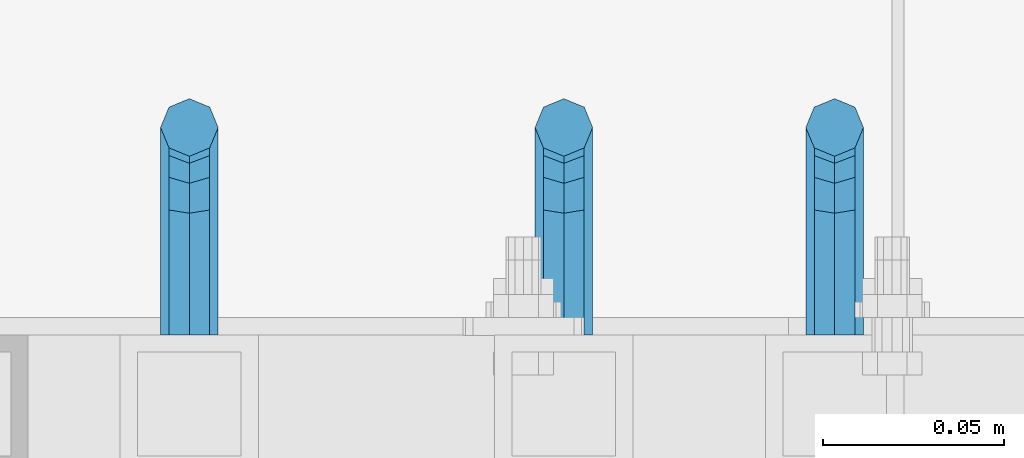
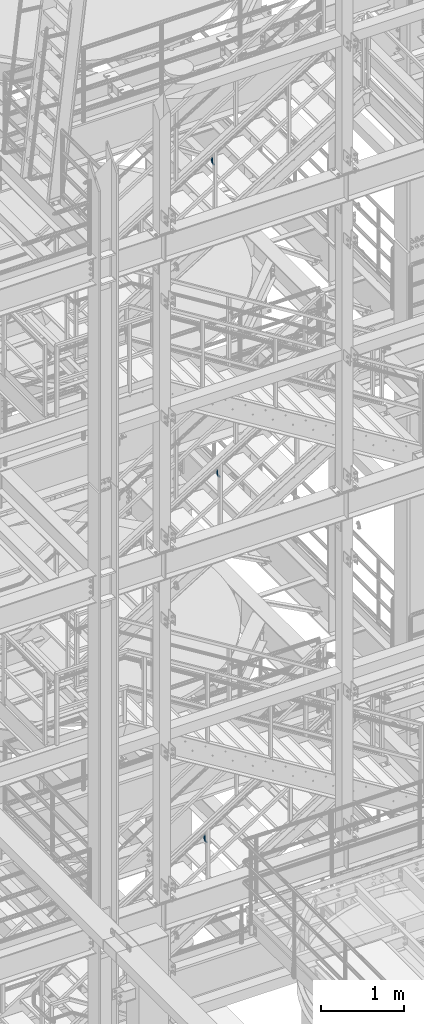
# One storey, part 1184 of 1876: 3 beams, 3 elements without a shape of their own.
"""IFC2X3 building model written with IfcOpenShell, lengths in millimetres."""

from ifc_helpers import new_model, si_unit, frame, origin_with_axes, place, context, subcontext, project, spatial, faceted_brep, material, type_object, element, aggregate, save


model = new_model("IFC2X3")

# Units and contexts
model_context = context("Model", 3, precision=1e-05, world=origin_with_axes())
body_context = subcontext(model_context, "Body", "Model", "MODEL_VIEW")
ifc_project = project(units=[si_unit("LENGTHUNIT", "METRE", prefix="MILLI"), si_unit("AREAUNIT", "SQUARE_METRE"), si_unit("VOLUMEUNIT", "CUBIC_METRE"), si_unit("MASSUNIT", "GRAM", prefix="KILO"), si_unit("TIMEUNIT", "SECOND"), si_unit("PLANEANGLEUNIT", "RADIAN"), si_unit("SOLIDANGLEUNIT", "STERADIAN"), si_unit("THERMODYNAMICTEMPERATUREUNIT", "DEGREE_CELSIUS"), si_unit("LUMINOUSINTENSITYUNIT", "LUMEN")], contexts=[model_context])

# Site, building, storey
site_placement = place(None, origin_with_axes())
site = spatial("IfcSite", under=ifc_project, at=site_placement, CompositionType="ELEMENT")
building_placement = place(site_placement, origin_with_axes())
building = spatial("IfcBuilding", under=site, at=building_placement, Name="Undefined", CompositionType="ELEMENT")
storey_placement = place(building_placement, origin_with_axes())
storey = spatial("IfcBuildingStorey", under=building, at=storey_placement, Name="Undefined", CompositionType="ELEMENT", Elevation=0.0)

# Assembly, beam
assembly_1_placement = place(storey_placement, origin_with_axes())
assembly_1 = element("IfcElementAssembly", 1, at=assembly_1_placement, inside=storey, Name="RAIL", AssemblyPlace="NOTDEFINED", PredefinedType="RIGID_FRAME")
ifc_material = material(Name="STEEL/A36")
beam_type = type_object("IfcBeamType", PredefinedType="NOTDEFINED")
beam_1_placement = place(assembly_1_placement, frame((4152.90000017992, -5715.00000114554, 12949.3240268015), z_axis=(1.0, 0.0, 0.0), x_axis=(0.0, 1.0, 0.0)))
beam_1 = element("IfcBeam", 2, at=beam_1_placement, type_object=beam_type, material=ifc_material, Name="BRACKET", context=body_context, shape_type="Brep", body=[
    faceted_brep([(0.0, -5.61266007566822, 5.61266007566883), (0.0, 0.0, 7.9375), (0.0, 5.61266007566822, 5.61266007566883), (0.0, 7.9375, 0.0), (0.0, 5.61266007566822, -5.61266007566883), (0.0, 0.0, -7.9375), (0.0, -5.61266007566822, -5.61266007566883), (0.0, -7.9375, 0.0), (23.8125, -5.61266007566883, -5.61266007566792), (23.8125, -7.9375, 0.0), (23.8125, -5.61266007566883, 5.61266007566792), (23.8125, 0.0, 7.9375), (23.8125, 5.61266007566883, 5.61266007566792), (23.8125, 7.9375, 0.0), (23.8125, 5.61266007566883, -5.61266007566792), (23.8125, 0.0, -7.9375), (36.5702095103998, 2.53766620105671, -7.9375), (38.7180815328556, -2.64775556579843, -5.61266007566792), (39.6077592547981, -4.79562758825341, 0.0), (38.7180815328556, -2.64775556579843, 5.61266007566792), (36.5702095103998, 2.53766620105671, 7.9375), (34.4223374879448, 7.72308796790821, 5.61266007566792), (33.5326597660023, 9.87095999036319, 0.0), (34.4223374879448, 7.72308796790821, -5.61266007566792), (43.4169233967659, 13.733078129113, -5.61266007566792), (47.3856733967659, 9.76432812911298, -7.9375), (41.773013321098, 15.3769882047818, 0.0), (43.4169233967659, 13.733078129113, 5.61266007566792), (47.3856733967659, 9.76432812911298, 7.9375), (51.3544233967659, 5.79557812911298, 5.61266007566792), (52.9983334724348, 4.15166805344415, 0.0), (51.3544233967659, 5.79557812911298, -5.61266007566792), (54.6123353248231, 20.5797920154801, -7.9375), (59.7977570916764, 18.4319199930251, -5.61266007566792), (49.4269135579698, 22.727664037935, -5.61266007566792), (47.2790415355148, 23.6173417598766, 0.0), (49.4269135579698, 22.727664037935, 5.61266007566792), (54.6123353248231, 20.5797920154801, 7.9375), (59.7977570916764, 18.4319199930251, 5.61266007566792), (61.9456291141314, 17.5422422710835, 0.0), (62.7626616015468, 33.3375015258789, -5.61266007566792), (65.0875015258789, 33.3375015258789, 0.0), (57.1500015258789, 33.3375015258789, -7.9375), (51.5373414502101, 33.3375015258789, -5.61266007566792), (49.2125015258789, 33.3375015258789, 0.0), (51.5373414502101, 33.3375015258789, 5.61266007566792), (57.1500015258789, 33.3375015258789, 7.9375), (62.7626616015468, 33.3375015258789, 5.61266007566792), (65.0875015258789, 66.6490606416592, 0.0), (62.7626616015468, 70.1016967070464, 5.61266007566792), (57.1500015258789, 71.5318253912683, 7.9375), (51.537341450211, 70.1016967070464, 5.61266007566792), (49.2125015258789, 66.6490606416592, 0.0), (51.537341450211, 63.1964245762738, -5.61266007566792), (57.1500015258789, 61.7662958920519, -7.9375), (62.7626616015468, 63.1964245762738, -5.61266007566792)], [[[0, 1, 2, 3, 4, 5, 6, 7]], [[7, 6, 8, 9]], [[0, 7, 9, 10]], [[1, 0, 10, 11]], [[2, 1, 11, 12]], [[3, 2, 12, 13]], [[4, 3, 13, 14]], [[5, 4, 14, 15]], [[6, 5, 15, 8]], [[8, 15, 16, 17]], [[9, 8, 17, 18]], [[10, 9, 18, 19]], [[11, 10, 19, 20]], [[12, 11, 20, 21]], [[13, 12, 21, 22]], [[14, 13, 22, 23]], [[15, 14, 23, 16]], [[23, 24, 25, 16]], [[22, 26, 24, 23]], [[21, 27, 26, 22]], [[20, 28, 27, 21]], [[19, 29, 28, 20]], [[18, 30, 29, 19]], [[17, 31, 30, 18]], [[16, 25, 31, 17]], [[25, 32, 33, 31]], [[24, 34, 32, 25]], [[26, 35, 34, 24]], [[27, 36, 35, 26]], [[28, 37, 36, 27]], [[29, 38, 37, 28]], [[30, 39, 38, 29]], [[31, 33, 39, 30]], [[33, 40, 41, 39]], [[32, 42, 40, 33]], [[34, 43, 42, 32]], [[35, 44, 43, 34]], [[36, 45, 44, 35]], [[37, 46, 45, 36]], [[38, 47, 46, 37]], [[39, 41, 47, 38]], [[47, 41, 48, 49]], [[46, 47, 49, 50]], [[45, 46, 50, 51]], [[44, 45, 51, 52]], [[43, 44, 52, 53]], [[42, 43, 53, 54]], [[40, 42, 54, 55]], [[41, 40, 55, 48]], [[54, 53, 52, 51, 50, 49, 48, 55]]]),
])
aggregate(assembly_1, [beam_1])

assembly_2_placement = place(storey_placement, origin_with_axes())
assembly_2 = element("IfcElementAssembly", 3, at=assembly_2_placement, inside=storey, Name="RAIL", AssemblyPlace="NOTDEFINED", PredefinedType="RIGID_FRAME")
beam_2_placement = place(assembly_2_placement, frame((4078.28749856572, -5715.00000114554, 17568.1944184702), z_axis=(1.0, 0.0, 0.0), x_axis=(0.0, 1.0, 0.0)))
beam_2 = element("IfcBeam", 4, at=beam_2_placement, type_object=beam_type, material=ifc_material, Name="BRACKET", context=body_context, shape_type="Brep", body=[
    faceted_brep([(0.0, -5.61266007566822, 5.61266007566883), (0.0, 0.0, 7.9375), (0.0, 5.61266007566822, 5.61266007566883), (0.0, 7.9375, 0.0), (0.0, 5.61266007566822, -5.61266007566883), (0.0, 0.0, -7.9375), (0.0, -5.61266007566822, -5.61266007566883), (0.0, -7.9375, 0.0), (23.8125, -5.61266007566883, -5.61266007566792), (23.8125, -7.9375, 0.0), (23.8125, -5.61266007566883, 5.61266007566792), (23.8125, 0.0, 7.9375), (23.8125, 5.61266007566883, 5.61266007566792), (23.8125, 7.9375, 0.0), (23.8125, 5.61266007566883, -5.61266007566792), (23.8125, 0.0, -7.9375), (36.5702095103998, 2.53766620105671, -7.9375), (38.7180815328556, -2.64775556579843, -5.61266007566792), (39.6077592547981, -4.79562758825341, 0.0), (38.7180815328556, -2.64775556579843, 5.61266007566792), (36.5702095103998, 2.53766620105671, 7.9375), (34.4223374879448, 7.72308796790821, 5.61266007566792), (33.5326597660023, 9.87095999036319, 0.0), (34.4223374879448, 7.72308796790821, -5.61266007566792), (43.4169233967659, 13.733078129113, -5.61266007566792), (47.3856733967659, 9.76432812911298, -7.9375), (41.773013321098, 15.3769882047818, 0.0), (43.4169233967659, 13.733078129113, 5.61266007566792), (47.3856733967659, 9.76432812911298, 7.9375), (51.3544233967659, 5.79557812911298, 5.61266007566792), (52.9983334724348, 4.15166805344415, 0.0), (51.3544233967659, 5.79557812911298, -5.61266007566792), (54.6123353248231, 20.5797920154801, -7.9375), (59.7977570916764, 18.4319199930251, -5.61266007566792), (49.4269135579698, 22.727664037935, -5.61266007566792), (47.2790415355148, 23.6173417598766, 0.0), (49.4269135579698, 22.727664037935, 5.61266007566792), (54.6123353248231, 20.5797920154801, 7.9375), (59.7977570916764, 18.4319199930251, 5.61266007566792), (61.9456291141314, 17.5422422710835, 0.0), (62.7626616015468, 33.3375015258789, -5.61266007566792), (65.0875015258789, 33.3375015258789, 0.0), (57.1500015258789, 33.3375015258789, -7.9375), (51.5373414502101, 33.3375015258789, -5.61266007566792), (49.2125015258789, 33.3375015258789, 0.0), (51.5373414502101, 33.3375015258789, 5.61266007566792), (57.1500015258789, 33.3375015258789, 7.9375), (62.7626616015468, 33.3375015258789, 5.61266007566792), (65.0875015258789, 66.4903820289292, 0.0), (62.7626616015468, 69.9676002640044, 5.61266007566837), (57.1500015258789, 71.4079051966655, 7.9375), (51.537341450211, 69.9676002640044, 5.61266007566837), (49.2125015258789, 66.4903820289292, 0.0), (51.537341450211, 63.0131928592527, -5.61266007566837), (57.1500015258789, 61.5728879265953, -7.9375), (62.7626616015468, 63.0131928592527, -5.61266007566837)], [[[0, 1, 2, 3, 4, 5, 6, 7]], [[7, 6, 8, 9]], [[0, 7, 9, 10]], [[1, 0, 10, 11]], [[2, 1, 11, 12]], [[3, 2, 12, 13]], [[4, 3, 13, 14]], [[5, 4, 14, 15]], [[6, 5, 15, 8]], [[8, 15, 16, 17]], [[9, 8, 17, 18]], [[10, 9, 18, 19]], [[11, 10, 19, 20]], [[12, 11, 20, 21]], [[13, 12, 21, 22]], [[14, 13, 22, 23]], [[15, 14, 23, 16]], [[23, 24, 25, 16]], [[22, 26, 24, 23]], [[21, 27, 26, 22]], [[20, 28, 27, 21]], [[19, 29, 28, 20]], [[18, 30, 29, 19]], [[17, 31, 30, 18]], [[16, 25, 31, 17]], [[25, 32, 33, 31]], [[24, 34, 32, 25]], [[26, 35, 34, 24]], [[27, 36, 35, 26]], [[28, 37, 36, 27]], [[29, 38, 37, 28]], [[30, 39, 38, 29]], [[31, 33, 39, 30]], [[33, 40, 41, 39]], [[32, 42, 40, 33]], [[34, 43, 42, 32]], [[35, 44, 43, 34]], [[36, 45, 44, 35]], [[37, 46, 45, 36]], [[38, 47, 46, 37]], [[39, 41, 47, 38]], [[47, 41, 48, 49]], [[46, 47, 49, 50]], [[45, 46, 50, 51]], [[44, 45, 51, 52]], [[43, 44, 52, 53]], [[42, 43, 53, 54]], [[40, 42, 54, 55]], [[41, 40, 55, 48]], [[54, 53, 52, 51, 50, 49, 48, 55]]]),
])
aggregate(assembly_2, [beam_2])

assembly_3_placement = place(storey_placement, origin_with_axes())
assembly_3 = element("IfcElementAssembly", 5, at=assembly_3_placement, inside=storey, Name="RAIL", AssemblyPlace="NOTDEFINED", PredefinedType="RIGID_FRAME")
beam_3_placement = place(assembly_3_placement, frame((3975.09999663309, -5715.00000114554, 7638.761483878), z_axis=(1.0, 0.0, 0.0), x_axis=(0.0, 1.0, 0.0)))
beam_3 = element("IfcBeam", 6, at=beam_3_placement, type_object=beam_type, material=ifc_material, Name="BRACKET", context=body_context, shape_type="Brep", body=[
    faceted_brep([(0.0, -5.61266007566822, 5.61266007566883), (0.0, 0.0, 7.9375), (0.0, 5.61266007566822, 5.61266007566883), (0.0, 7.9375, 0.0), (0.0, 5.61266007566822, -5.61266007566883), (0.0, 0.0, -7.9375), (0.0, -5.61266007566822, -5.61266007566883), (0.0, -7.9375, 0.0), (23.8125, -5.61266007566883, -5.61266007566792), (23.8125, -7.9375, 0.0), (23.8125, -5.61266007566883, 5.61266007566792), (23.8125, 0.0, 7.9375), (23.8125, 5.61266007566883, 5.61266007566792), (23.8125, 7.9375, 0.0), (23.8125, 5.61266007566883, -5.61266007566792), (23.8125, 0.0, -7.9375), (36.5702095103998, 2.53766620105671, -7.9375), (38.7180815328556, -2.64775556579843, -5.61266007566792), (39.6077592547981, -4.79562758825341, 0.0), (38.7180815328556, -2.64775556579843, 5.61266007566792), (36.5702095103998, 2.53766620105671, 7.9375), (34.4223374879448, 7.72308796790821, 5.61266007566792), (33.5326597660023, 9.87095999036319, 0.0), (34.4223374879448, 7.72308796790821, -5.61266007566792), (43.4169233967659, 13.733078129113, -5.61266007566792), (47.3856733967659, 9.76432812911298, -7.9375), (41.773013321098, 15.3769882047818, 0.0), (43.4169233967659, 13.733078129113, 5.61266007566792), (47.3856733967659, 9.76432812911298, 7.9375), (51.3544233967659, 5.79557812911298, 5.61266007566792), (52.9983334724348, 4.15166805344415, 0.0), (51.3544233967659, 5.79557812911298, -5.61266007566792), (54.6123353248231, 20.5797920154801, -7.9375), (59.7977570916764, 18.4319199930251, -5.61266007566792), (49.4269135579698, 22.727664037935, -5.61266007566792), (47.2790415355148, 23.6173417598766, 0.0), (49.4269135579698, 22.727664037935, 5.61266007566792), (54.6123353248231, 20.5797920154801, 7.9375), (59.7977570916764, 18.4319199930251, 5.61266007566792), (61.9456291141314, 17.5422422710835, 0.0), (62.7626616015468, 33.3375015258789, -5.61266007566792), (65.0875015258789, 33.3375015258789, 0.0), (57.1500015258789, 33.3375015258789, -7.9375), (51.5373414502101, 33.3375015258789, -5.61266007566792), (49.2125015258789, 33.3375015258789, 0.0), (51.5373414502101, 33.3375015258789, 5.61266007566792), (57.1500015258789, 33.3375015258789, 7.9375), (62.7626616015468, 33.3375015258789, 5.61266007566792), (65.0875015258789, 66.3198431774908, 4.46561898570508e-10), (62.7626616015423, 69.8915357799633, 5.61266007614358), (57.1500015258725, 71.370979296531, 7.93750000048021), (51.5373414502064, 69.891535779956, 5.61266007613449), (49.2125015258789, 66.3198431774854, 4.38376446254551e-10), (51.5373414502164, 62.7481505750166, -5.61266007525228), (57.150001525888, 61.2687070584507, -7.937499999588), (62.7626616015532, 62.7481505750256, -5.61266007523955)], [[[0, 1, 2, 3, 4, 5, 6, 7]], [[7, 6, 8, 9]], [[0, 7, 9, 10]], [[1, 0, 10, 11]], [[2, 1, 11, 12]], [[3, 2, 12, 13]], [[4, 3, 13, 14]], [[5, 4, 14, 15]], [[6, 5, 15, 8]], [[8, 15, 16, 17]], [[9, 8, 17, 18]], [[10, 9, 18, 19]], [[11, 10, 19, 20]], [[12, 11, 20, 21]], [[13, 12, 21, 22]], [[14, 13, 22, 23]], [[15, 14, 23, 16]], [[23, 24, 25, 16]], [[22, 26, 24, 23]], [[21, 27, 26, 22]], [[20, 28, 27, 21]], [[19, 29, 28, 20]], [[18, 30, 29, 19]], [[17, 31, 30, 18]], [[16, 25, 31, 17]], [[25, 32, 33, 31]], [[24, 34, 32, 25]], [[26, 35, 34, 24]], [[27, 36, 35, 26]], [[28, 37, 36, 27]], [[29, 38, 37, 28]], [[30, 39, 38, 29]], [[31, 33, 39, 30]], [[33, 40, 41, 39]], [[32, 42, 40, 33]], [[34, 43, 42, 32]], [[35, 44, 43, 34]], [[36, 45, 44, 35]], [[37, 46, 45, 36]], [[38, 47, 46, 37]], [[39, 41, 47, 38]], [[47, 41, 48, 49]], [[46, 47, 49, 50]], [[45, 46, 50, 51]], [[44, 45, 51, 52]], [[43, 44, 52, 53]], [[42, 43, 53, 54]], [[40, 42, 54, 55]], [[41, 40, 55, 48]], [[54, 53, 52, 51, 50, 49, 48, 55]]]),
])
aggregate(assembly_3, [beam_3])

save(model, "model.ifc")
